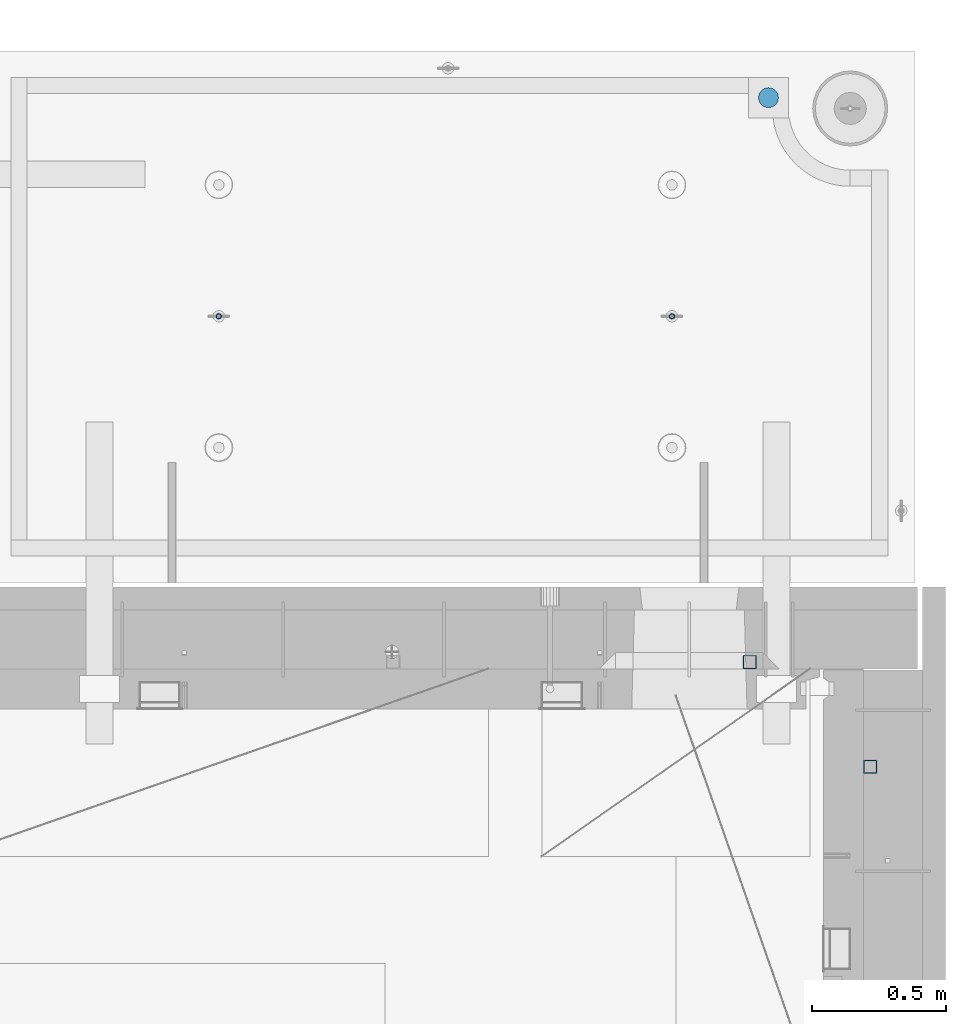
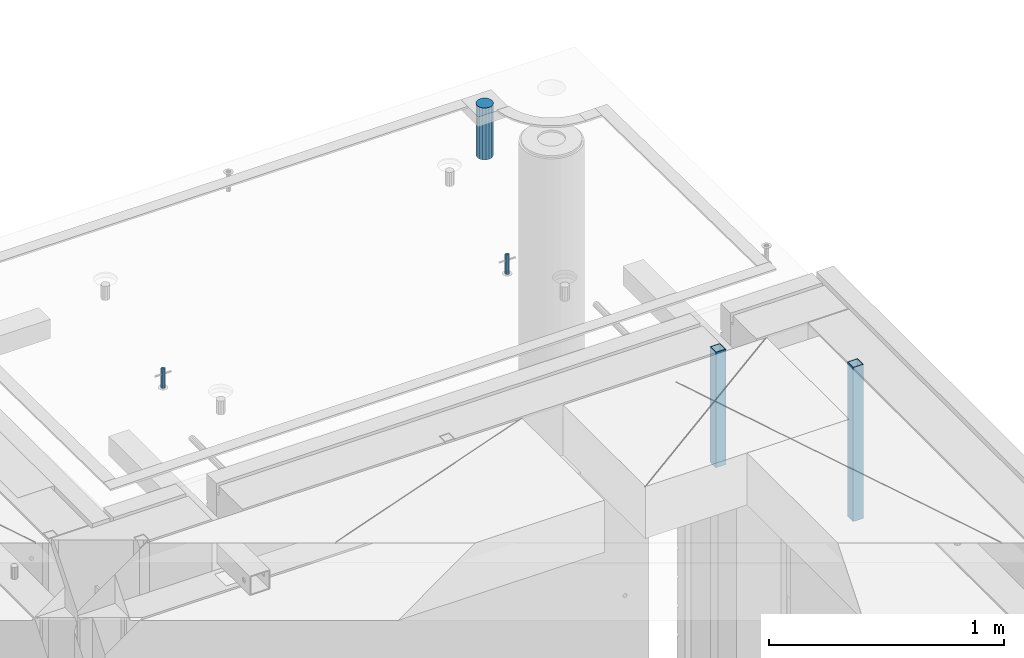
# One storey, part 37 of 352: 5 columns, 7 elements without a shape of their own.
"""IFC2X3 building model written with IfcOpenShell, lengths in millimetres."""

from ifc_helpers import new_model, si_unit, frame, origin_with_axes, place, context, subcontext, project, spatial, faceted_brep, material, type_object, element, aggregate, save


model = new_model("IFC2X3")

# Units and contexts
model_context = context("Model", 3, precision=1e-05, world=origin_with_axes())
body_context = subcontext(model_context, "Body", "Model", "MODEL_VIEW")
ifc_project = project(units=[si_unit("LENGTHUNIT", "METRE", prefix="MILLI"), si_unit("AREAUNIT", "SQUARE_METRE"), si_unit("VOLUMEUNIT", "CUBIC_METRE"), si_unit("MASSUNIT", "GRAM", prefix="KILO"), si_unit("TIMEUNIT", "SECOND"), si_unit("PLANEANGLEUNIT", "RADIAN"), si_unit("SOLIDANGLEUNIT", "STERADIAN"), si_unit("THERMODYNAMICTEMPERATUREUNIT", "DEGREE_CELSIUS"), si_unit("LUMINOUSINTENSITYUNIT", "LUMEN")], contexts=[model_context])

# Site, building, storey
site_placement = place(None, origin_with_axes())
site = spatial("IfcSite", under=ifc_project, at=site_placement, CompositionType="ELEMENT")
building_placement = place(site_placement, origin_with_axes())
building = spatial("IfcBuilding", under=site, at=building_placement, CompositionType="ELEMENT")
storey_placement = place(building_placement, origin_with_axes())
storey = spatial("IfcBuildingStorey", under=building, at=storey_placement, Name="6", CompositionType="ELEMENT", Elevation=0.0)

# Assemblies, column
assembly_1_placement = place(storey_placement, origin_with_axes())
assembly_1 = element("IfcElementAssembly", 1, at=assembly_1_placement, inside=storey, AssemblyPlace="NOTDEFINED", PredefinedType="REINFORCEMENT_UNIT")
assembly_2_placement = place(assembly_1_placement, origin_with_axes())
assembly_2 = element("IfcElementAssembly", 2, at=assembly_2_placement, Name="Steel Assembly", AssemblyPlace="NOTDEFINED", PredefinedType="RIGID_FRAME")
aggregate(assembly_1, [assembly_2])
ifc_material_1 = material(Name="STEEL/S355J2")
column_type_1 = type_object("IfcColumnType", Name="50X50X3", PredefinedType="NOTDEFINED")
column_1_placement = place(assembly_2_placement, frame((34635.0, 20605.0, 99140.0), z_axis=(1.0, 0.0, 0.0), x_axis=(0.0, 0.0, 1.0)))
column_1 = element("IfcColumn", 3, at=column_1_placement, type_object=column_type_1, material=ifc_material_1, ObjectType="50X50X3", context=body_context, shape_type="Brep", body=[
    faceted_brep([(0.0, 22.0, -22.0), (0.0, -22.0, -22.0), (600.0, -22.0, -22.0), (600.0, 22.0, -22.0), (0.0, -22.0, 22.0), (600.0, -22.0, 22.0), (0.0, 22.0, 22.0), (600.0, 22.0, 22.0), (0.0, 25.0, -25.0), (0.0, 25.0, 25.0), (600.0, 25.0, 25.0), (600.0, 25.0, -25.0), (0.0, -25.0, 25.0), (600.0, -25.0, 25.0), (0.0, -25.0, -25.0), (600.0, -25.0, -25.0)], [[[0, 1, 2, 3]], [[1, 4, 5, 2]], [[4, 6, 7, 5]], [[6, 0, 3, 7]], [[8, 9, 10, 11]], [[9, 12, 13, 10]], [[12, 14, 15, 13]], [[14, 8, 11, 15]], [[13, 15, 11, 10], [5, 7, 3, 2]], [[14, 12, 9, 8], [6, 4, 1, 0]]]),
])
aggregate(assembly_2, [column_1])

assembly_3_placement = place(storey_placement, origin_with_axes())
assembly_3 = element("IfcElementAssembly", 4, at=assembly_3_placement, inside=storey, AssemblyPlace="NOTDEFINED", PredefinedType="REINFORCEMENT_UNIT")
assembly_4_placement = place(assembly_3_placement, origin_with_axes())
assembly_4 = element("IfcElementAssembly", 5, at=assembly_4_placement, Name="Steel Assembly", AssemblyPlace="NOTDEFINED", PredefinedType="RIGID_FRAME")
aggregate(assembly_3, [assembly_4])
column_2_placement = place(assembly_4_placement, frame((35085.0, 20215.0002861023, 98940.0), z_axis=(0.0, -1.0, 0.0), x_axis=(0.0, 0.0, 1.0)))
column_2 = element("IfcColumn", 6, at=column_2_placement, type_object=column_type_1, material=ifc_material_1, ObjectType="50X50X3", context=body_context, shape_type="Brep", body=[
    faceted_brep([(0.0, 22.0, -22.0), (0.0, -22.0, -22.0), (800.0, -22.0, -22.0), (800.0, 22.0, -22.0), (0.0, -22.0, 22.0), (800.0, -22.0, 22.0), (0.0, 22.0, 22.0), (800.0, 22.0, 22.0), (0.0, 25.0, -25.0), (0.0, 25.0, 25.0), (800.0, 25.0, 25.0), (800.0, 25.0, -25.0), (0.0, -25.0, 25.0), (800.0, -25.0, 25.0), (0.0, -25.0, -25.0), (800.0, -25.0, -25.0)], [[[0, 1, 2, 3]], [[1, 4, 5, 2]], [[4, 6, 7, 5]], [[6, 0, 3, 7]], [[8, 9, 10, 11]], [[9, 12, 13, 10]], [[12, 14, 15, 13]], [[14, 8, 11, 15]], [[13, 15, 11, 10], [5, 7, 3, 2]], [[14, 12, 9, 8], [6, 4, 1, 0]]]),
])
aggregate(assembly_4, [column_2])

# Assemblies, columns
assembly_5_placement = place(storey_placement, origin_with_axes())
assembly_5 = element("IfcElementAssembly", 7, at=assembly_5_placement, inside=storey, AssemblyPlace="NOTDEFINED", PredefinedType="REINFORCEMENT_UNIT")
assembly_6_placement = place(assembly_5_placement, origin_with_axes())
assembly_6 = element("IfcElementAssembly", 8, at=assembly_6_placement, Name="Steel Assembly", AssemblyPlace="NOTDEFINED", PredefinedType="RIGID_FRAME")
ifc_material_2 = material(Name="STEEL/1.4301")
column_type_2 = type_object("IfcColumnType", PredefinedType="NOTDEFINED")
column_3_placement = place(assembly_6_placement, frame((32654.9901431868, 21895.0034426477, 99445.0), z_axis=(0.000321686000089053, -0.999999948259057, 0.0), x_axis=(0.0, 0.0, 1.0)))
column_3 = element("IfcColumn", 9, at=column_3_placement, type_object=column_type_2, material=ifc_material_2, context=body_context, shape_type="Brep", body=[
    faceted_brep([(0.0, -8.0, 0.0), (0.0, -6.92820323027263, 4.0), (100.000000000029, -6.92820323027263, 4.0), (100.000000000029, -7.99999999999636, 0.0), (0.0, -4.0, 6.92820323027627), (100.000000000029, -4.0, 6.92820323027536), (0.0, 0.0, 8.0), (100.000000000029, 3.63797880709171e-12, 8.0), (0.0, 4.0, 6.92820323027627), (100.000000000029, 4.0, 6.92820323027536), (0.0, 6.92820323027263, 4.0), (100.000000000029, 6.92820323027627, 3.99999999999909), (0.0, 8.0, 0.0), (100.000000000029, 8.0, 0.0), (0.0, 6.92820323027263, -4.0), (100.000000000029, 6.92820323027627, -4.00000000000091), (0.0, 4.0, -6.92820323027627), (100.000000000029, 4.00000000000364, -6.92820323027536), (0.0, 0.0, -8.0), (100.000000000029, 3.63797880709171e-12, -8.00000000000091), (0.0, -4.0, -6.92820323027627), (100.000000000029, -3.99999999999636, -6.92820323027627), (0.0, -6.92820323027263, -4.0), (100.000000000029, -6.92820323027263, -4.0), (0.0, -10.4999999999927, -1.45519152283669e-11), (0.0, -9.09326673972828, -5.25000000001455), (100.000000000262, -9.09326673972828, -5.25000000001455), (100.000000000262, -10.4999999999927, -1.45519152283669e-11), (0.0, -5.24999999998545, -9.09326673974283), (100.000000000262, -5.24999999998545, -9.09326673974283), (0.0, 7.27595761418343e-12, -10.5), (100.000000000262, 7.27595761418343e-12, -10.5), (0.0, 5.25000000001455, -9.09326673975738), (100.000000000262, 5.25000000001455, -9.09326673975738), (0.0, 9.09326673975011, -5.25000000001455), (100.000000000262, 9.09326673975011, -5.25000000001455), (0.0, 10.5000000000073, -1.45519152283669e-11), (100.000000000262, 10.5000000000073, -1.45519152283669e-11), (0.0, 9.09326673975011, 5.25), (100.000000000262, 9.09326673975011, 5.25), (0.0, 5.25000000000728, 9.09326673972828), (100.000000000262, 5.25000000000728, 9.09326673972828), (0.0, 1.45519152283669e-11, 10.4999999999854), (100.000000000262, 1.45519152283669e-11, 10.4999999999854), (0.0, -5.24999999999272, 9.09326673972828), (100.000000000262, -5.24999999999272, 9.09326673972828), (0.0, -9.09326673972828, 5.24999999998545), (100.000000000262, -9.09326673972828, 5.24999999998545)], [[[0, 1, 2, 3]], [[1, 4, 5, 2]], [[4, 6, 7, 5]], [[6, 8, 9, 7]], [[8, 10, 11, 9]], [[10, 12, 13, 11]], [[12, 14, 15, 13]], [[14, 16, 17, 15]], [[16, 18, 19, 17]], [[18, 20, 21, 19]], [[20, 22, 23, 21]], [[22, 0, 3, 23]], [[24, 25, 26, 27]], [[25, 28, 29, 26]], [[28, 30, 31, 29]], [[30, 32, 33, 31]], [[32, 34, 35, 33]], [[34, 36, 37, 35]], [[36, 38, 39, 37]], [[38, 40, 41, 39]], [[40, 42, 43, 41]], [[42, 44, 45, 43]], [[44, 46, 47, 45]], [[46, 24, 27, 47]], [[29, 31, 33, 35, 37, 39, 41, 43, 45, 47, 27, 26], [5, 7, 9, 11, 13, 15, 17, 19, 21, 23, 3, 2]], [[46, 44, 42, 40, 38, 36, 34, 32, 30, 28, 25, 24], [22, 20, 18, 16, 14, 12, 10, 8, 6, 4, 1, 0]]]),
])
aggregate(assembly_6, [column_3])
assembly_7_placement = place(assembly_5_placement, origin_with_axes())
assembly_7 = element("IfcElementAssembly", 10, at=assembly_7_placement, Name="Steel Assembly", AssemblyPlace="NOTDEFINED", PredefinedType="RIGID_FRAME")
column_4_placement = place(assembly_7_placement, frame((34345.0001431868, 21895.0034426477, 99445.0), z_axis=(0.000321686000089053, -0.999999948259057, 0.0), x_axis=(0.0, 0.0, 1.0)))
column_4 = element("IfcColumn", 11, at=column_4_placement, type_object=column_type_2, material=ifc_material_2, context=body_context, shape_type="Brep", body=[
    faceted_brep([(0.0, -8.0, 0.0), (0.0, -6.92820323027263, 4.0), (100.000000000029, -6.92820323027263, 4.0), (100.000000000029, -7.99999999999636, 0.0), (0.0, -4.0, 6.92820323027627), (100.000000000029, -4.0, 6.92820323027536), (0.0, 0.0, 8.0), (100.000000000029, 3.63797880709171e-12, 8.0), (0.0, 4.0, 6.92820323027627), (100.000000000029, 4.0, 6.92820323027536), (0.0, 6.92820323027263, 4.0), (100.000000000029, 6.92820323027627, 3.99999999999909), (0.0, 8.0, 0.0), (100.000000000029, 8.0, 0.0), (0.0, 6.92820323027263, -4.0), (100.000000000029, 6.92820323027627, -4.00000000000091), (0.0, 4.0, -6.92820323027627), (100.000000000029, 4.00000000000364, -6.92820323027536), (0.0, 0.0, -8.0), (100.000000000029, 3.63797880709171e-12, -8.00000000000091), (0.0, -4.0, -6.92820323027627), (100.000000000029, -3.99999999999636, -6.92820323027627), (0.0, -6.92820323027263, -4.0), (100.000000000029, -6.92820323027263, -4.0), (0.0, -10.4999999999927, -1.45519152283669e-11), (0.0, -9.09326673972828, -5.25000000001455), (100.000000000262, -9.09326673972828, -5.25000000001455), (100.000000000262, -10.4999999999927, -1.45519152283669e-11), (0.0, -5.24999999998545, -9.09326673974283), (100.000000000262, -5.24999999998545, -9.09326673974283), (0.0, 7.27595761418343e-12, -10.5), (100.000000000262, 7.27595761418343e-12, -10.5), (0.0, 5.25000000001455, -9.09326673975738), (100.000000000262, 5.25000000001455, -9.09326673975738), (0.0, 9.09326673975011, -5.25000000001455), (100.000000000262, 9.09326673975011, -5.25000000001455), (0.0, 10.5000000000073, -1.45519152283669e-11), (100.000000000262, 10.5000000000073, -1.45519152283669e-11), (0.0, 9.09326673975011, 5.25), (100.000000000262, 9.09326673975011, 5.25), (0.0, 5.25000000000728, 9.09326673972828), (100.000000000262, 5.25000000000728, 9.09326673972828), (0.0, 1.45519152283669e-11, 10.4999999999854), (100.000000000262, 1.45519152283669e-11, 10.4999999999854), (0.0, -5.24999999999272, 9.09326673972828), (100.000000000262, -5.24999999999272, 9.09326673972828), (0.0, -9.09326673972828, 5.24999999998545), (100.000000000262, -9.09326673972828, 5.24999999998545)], [[[0, 1, 2, 3]], [[1, 4, 5, 2]], [[4, 6, 7, 5]], [[6, 8, 9, 7]], [[8, 10, 11, 9]], [[10, 12, 13, 11]], [[12, 14, 15, 13]], [[14, 16, 17, 15]], [[16, 18, 19, 17]], [[18, 20, 21, 19]], [[20, 22, 23, 21]], [[22, 0, 3, 23]], [[24, 25, 26, 27]], [[25, 28, 29, 26]], [[28, 30, 31, 29]], [[30, 32, 33, 31]], [[32, 34, 35, 33]], [[34, 36, 37, 35]], [[36, 38, 39, 37]], [[38, 40, 41, 39]], [[40, 42, 43, 41]], [[42, 44, 45, 43]], [[44, 46, 47, 45]], [[46, 24, 27, 47]], [[29, 31, 33, 35, 37, 39, 41, 43, 45, 47, 27, 26], [5, 7, 9, 11, 13, 15, 17, 19, 21, 23, 3, 2]], [[46, 44, 42, 40, 38, 36, 34, 32, 30, 28, 25, 24], [22, 20, 18, 16, 14, 12, 10, 8, 6, 4, 1, 0]]]),
])
aggregate(assembly_7, [column_4])
ifc_material_3 = material()
column_type_3 = type_object("IfcColumnType", Name="D75", PredefinedType="NOTDEFINED")
column_5_placement = place(assembly_5_placement, frame((34704.9998568133, 22710.1651093338, 99440.0), z_axis=(0.9999999949993, 0.000100007000000845, 0.0), x_axis=(0.0, 0.0, 1.0)))
column_5 = element("IfcColumn", 12, at=column_5_placement, type_object=column_type_3, material=ifc_material_3, ObjectType="D75", context=body_context, shape_type="Brep", body=[
    faceted_brep([(0.0, -37.4999999999991, 1.81898940354586e-12), (0.0, -34.6454824691718, -14.3506287136888), (270.0, -34.6454824691718, -14.3506287136888), (270.0, -37.4999999999991, 1.81898940354586e-12), (0.0, -26.5165042944936, -26.5165042944936), (270.0, -26.5165042944936, -26.5165042944936), (0.0, -14.3506287136906, -34.6454824691718), (270.0, -14.3506287136906, -34.6454824691718), (0.0, 9.09494701772928e-13, -37.4999999999982), (270.0, 9.09494701772928e-13, -37.4999999999982), (0.0, 14.3506287136915, -34.6454824691718), (270.0, 14.3506287136915, -34.6454824691718), (0.0, 26.5165042944973, -26.5165042944927), (270.0, 26.5165042944973, -26.5165042944927), (0.0, 34.6454824691746, -14.3506287136897), (270.0, 34.6454824691746, -14.3506287136897), (0.0, 37.5000000000018, 1.81898940354586e-12), (270.0, 37.5000000000018, 1.81898940354586e-12), (0.0, 34.6454824691755, 14.3506287136925), (270.0, 34.6454824691755, 14.3506287136925), (0.0, 26.5165042944964, 26.5165042944973), (270.0, 26.5165042944964, 26.5165042944973), (0.0, 14.3506287136934, 34.6454824691755), (270.0, 14.3506287136934, 34.6454824691755), (0.0, 1.81898940354586e-12, 37.5000000000027), (270.0, 1.81898940354586e-12, 37.5000000000027), (0.0, -14.3506287136897, 34.6454824691746), (270.0, -14.3506287136897, 34.6454824691746), (0.0, -26.5165042944946, 26.5165042944973), (270.0, -26.5165042944946, 26.5165042944973), (0.0, -34.6454824691718, 14.3506287136925), (270.0, -34.6454824691718, 14.3506287136925)], [[[0, 1, 2, 3]], [[1, 4, 5, 2]], [[4, 6, 7, 5]], [[6, 8, 9, 7]], [[8, 10, 11, 9]], [[10, 12, 13, 11]], [[12, 14, 15, 13]], [[14, 16, 17, 15]], [[16, 18, 19, 17]], [[18, 20, 21, 19]], [[20, 22, 23, 21]], [[22, 24, 25, 23]], [[24, 26, 27, 25]], [[26, 28, 29, 27]], [[28, 30, 31, 29]], [[30, 0, 3, 31]], [[5, 7, 9, 11, 13, 15, 17, 19, 21, 23, 25, 27, 29, 31, 3, 2]], [[30, 28, 26, 24, 22, 20, 18, 16, 14, 12, 10, 8, 6, 4, 1, 0]]]),
])
aggregate(assembly_5, [assembly_6, assembly_7, column_5])

save(model, "model.ifc")
